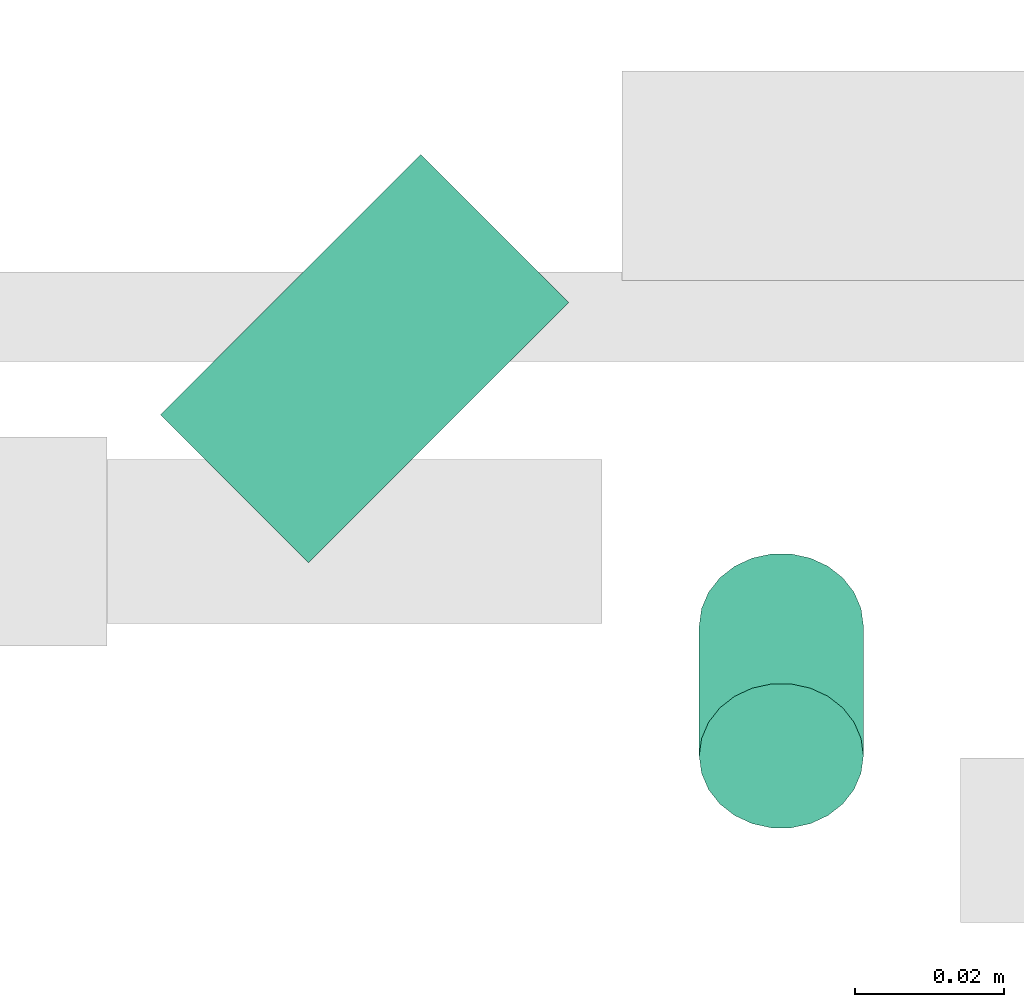
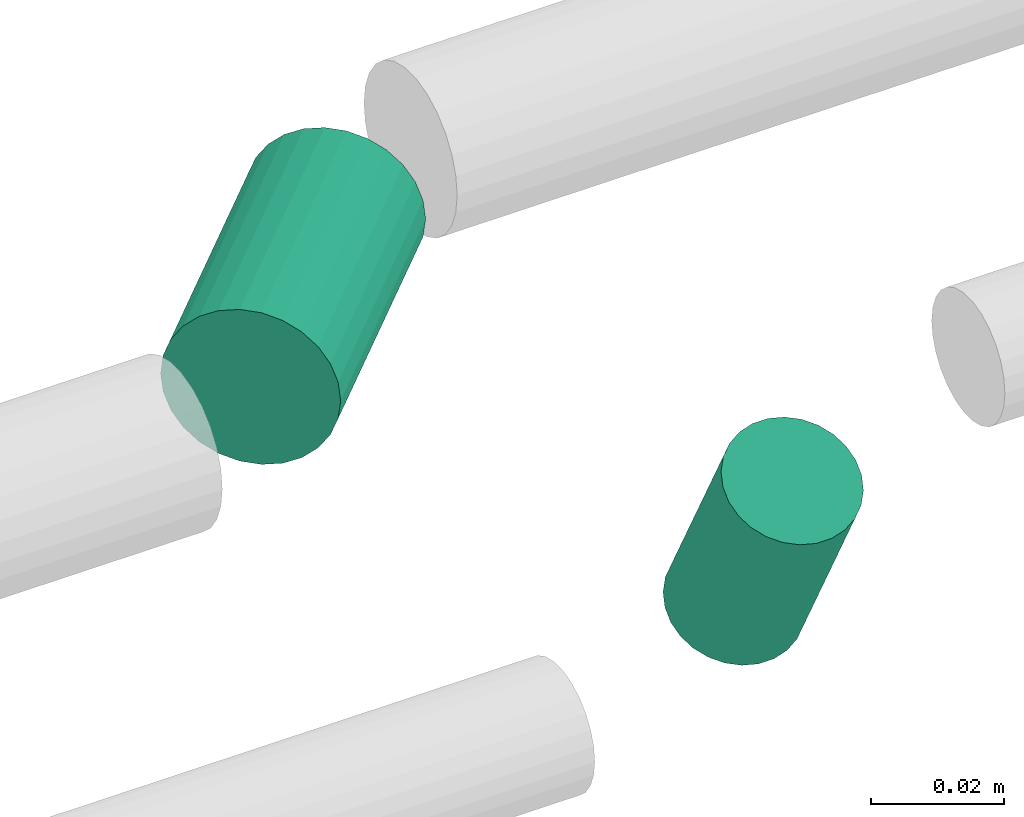
# One storey, part 279 of 331: 2 flow segments.
"""IFC2X3 building model written with IfcOpenShell, lengths in millimetres."""

from ifc_helpers import new_model, entity, si_unit, converted_unit, derived_unit, direction, frame, origin, origin_2d_with_axis, place, context, subcontext, project, spatial, circle, extrude, type_object, element, save


model = new_model("IFC2X3")

# Units and contexts
model_context = context("Model", 3, precision=0.01, world=origin(), true_north=direction((6.12303176911189e-17, 1.0)))
body_context = subcontext(model_context, "Body", "Model", "MODEL_VIEW")
ifc_project = project(units=[si_unit("LENGTHUNIT", "METRE", prefix="MILLI"), si_unit("AREAUNIT", "SQUARE_METRE"), si_unit("VOLUMEUNIT", "CUBIC_METRE"), converted_unit("PLANEANGLEUNIT", "DEGREE", entity("IfcRatioMeasure", 0.0174532925199433), si_unit("PLANEANGLEUNIT", "RADIAN"), dimensions=[0, 0, 0, 0, 0, 0, 0]), si_unit("MASSUNIT", "GRAM", prefix="KILO"), derived_unit("MASSDENSITYUNIT", [(si_unit("MASSUNIT", "GRAM", prefix="KILO"), 1), (si_unit("LENGTHUNIT", "METRE"), -3)]), derived_unit("MOMENTOFINERTIAUNIT", [(si_unit("LENGTHUNIT", "METRE"), 4)]), si_unit("TIMEUNIT", "SECOND"), si_unit("FREQUENCYUNIT", "HERTZ"), si_unit("THERMODYNAMICTEMPERATUREUNIT", "DEGREE_CELSIUS"), derived_unit("THERMALTRANSMITTANCEUNIT", [(si_unit("MASSUNIT", "GRAM", prefix="KILO"), 1), (si_unit("THERMODYNAMICTEMPERATUREUNIT", "KELVIN"), -1), (si_unit("TIMEUNIT", "SECOND"), -3)]), derived_unit("VOLUMETRICFLOWRATEUNIT", [(si_unit("LENGTHUNIT", "METRE"), 3), (si_unit("TIMEUNIT", "SECOND"), -1)]), derived_unit("MASSFLOWRATEUNIT", [(si_unit("MASSUNIT", "GRAM", prefix="KILO"), 1), (si_unit("TIMEUNIT", "SECOND"), -1)]), derived_unit("ROTATIONALFREQUENCYUNIT", [(si_unit("TIMEUNIT", "SECOND"), -1)]), si_unit("ELECTRICCURRENTUNIT", "AMPERE"), si_unit("ELECTRICVOLTAGEUNIT", "VOLT"), si_unit("POWERUNIT", "WATT"), si_unit("FORCEUNIT", "NEWTON", prefix="KILO"), si_unit("ILLUMINANCEUNIT", "LUX"), si_unit("LUMINOUSFLUXUNIT", "LUMEN"), si_unit("LUMINOUSINTENSITYUNIT", "CANDELA"), derived_unit("USERDEFINED", [(si_unit("MASSUNIT", "GRAM", prefix="KILO"), -1), (si_unit("LENGTHUNIT", "METRE"), -2), (si_unit("TIMEUNIT", "SECOND"), 3), (si_unit("LUMINOUSFLUXUNIT", "LUMEN"), 1)]), derived_unit("LINEARVELOCITYUNIT", [(si_unit("LENGTHUNIT", "METRE"), 1), (si_unit("TIMEUNIT", "SECOND"), -1)]), si_unit("PRESSUREUNIT", "PASCAL"), derived_unit("USERDEFINED", [(si_unit("LENGTHUNIT", "METRE"), -2), (si_unit("MASSUNIT", "GRAM", prefix="KILO"), 1), (si_unit("TIMEUNIT", "SECOND"), -2)]), derived_unit("LINEARFORCEUNIT", [(si_unit("MASSUNIT", "GRAM", prefix="KILO"), 1), (si_unit("LENGTHUNIT", "METRE"), 1), (si_unit("TIMEUNIT", "SECOND"), -2), (si_unit("LENGTHUNIT", "METRE"), -1)]), derived_unit("PLANARFORCEUNIT", [(si_unit("MASSUNIT", "GRAM", prefix="KILO"), 1), (si_unit("LENGTHUNIT", "METRE"), 1), (si_unit("TIMEUNIT", "SECOND"), -2), (si_unit("LENGTHUNIT", "METRE"), -2)])], contexts=[model_context])

# Site, building, storey
site_placement = place(None, frame((0.0, -0.00077364408347762, 0.0)))
site = spatial("IfcSite", under=ifc_project, at=site_placement, CompositionType="ELEMENT")
building_placement = place(site_placement, origin())
building = spatial("IfcBuilding", under=site, at=building_placement, CompositionType="ELEMENT")
storey_placement = place(building_placement, origin())
storey = spatial("IfcBuildingStorey", under=building, at=storey_placement, CompositionType="ELEMENT", Elevation=0.0)

# Flow segments
pipe_segment_type = type_object("IfcPipeSegmentType", PredefinedType="NOTDEFINED")
flow_segment_1_placement = place(building_placement, frame((46025.0601986737, 8191.09256233188, 2759.40472776402)))
element("IfcFlowSegment", 1, at=flow_segment_1_placement, inside=storey, type_object=pipe_segment_type, context=body_context, shape_type="SweptSolid", body=[
    extrude(circle(Radius=14.0, at=origin_2d_with_axis()), frame((11.494767172538, 11.4947671725228, 15.595272235916), z_axis=(0.70710678118602, 0.707106781187075, 0.0), x_axis=(0.707106781187075, -0.70710678118602, 0.0)), (0.0, 0.0, 1.0), 49.2964645562435),
])
flow_segment_2_placement = place(building_placement, frame((46097.2030577144, 8155.50922475086, 2714.40472776403)))
element("IfcFlowSegment", 2, at=flow_segment_2_placement, inside=storey, type_object=pipe_segment_type, context=body_context, shape_type="SweptSolid", body=[
    extrude(circle(Radius=11.0, at=origin_2d_with_axis()), frame((12.5952722359134, 11.3011545888559, 39.4188016476788), z_axis=(0.0, 0.470588235294346, -0.882352941176349), x_axis=(1.0, 0.0, 0.0)), (0.0, 0.0, 1.0), 37.0000000000012),
])

save(model, "model.ifc")
